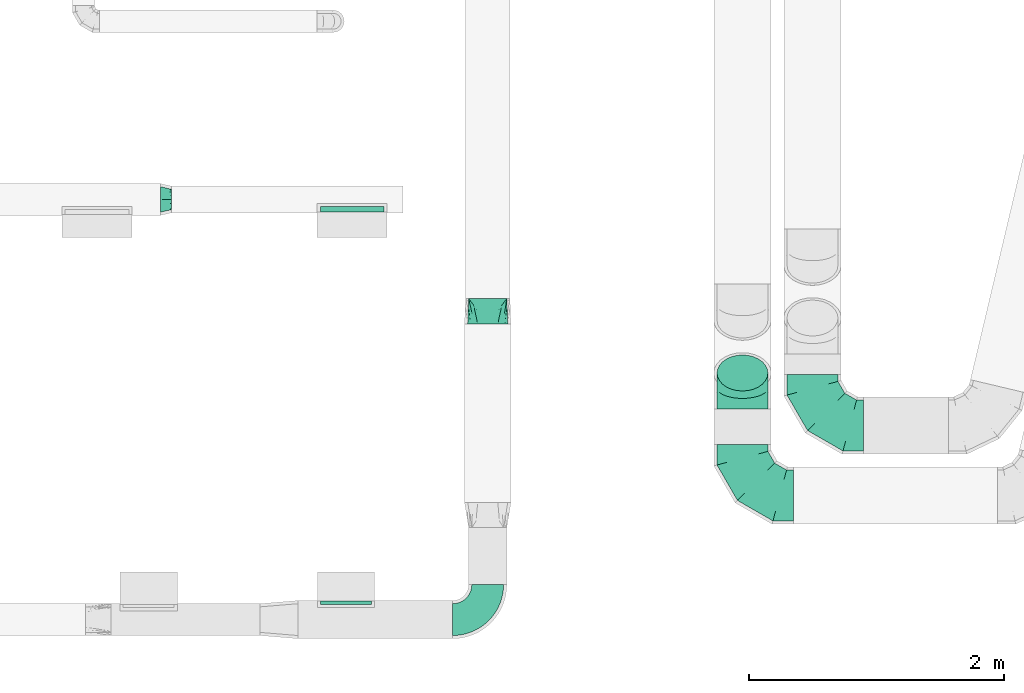
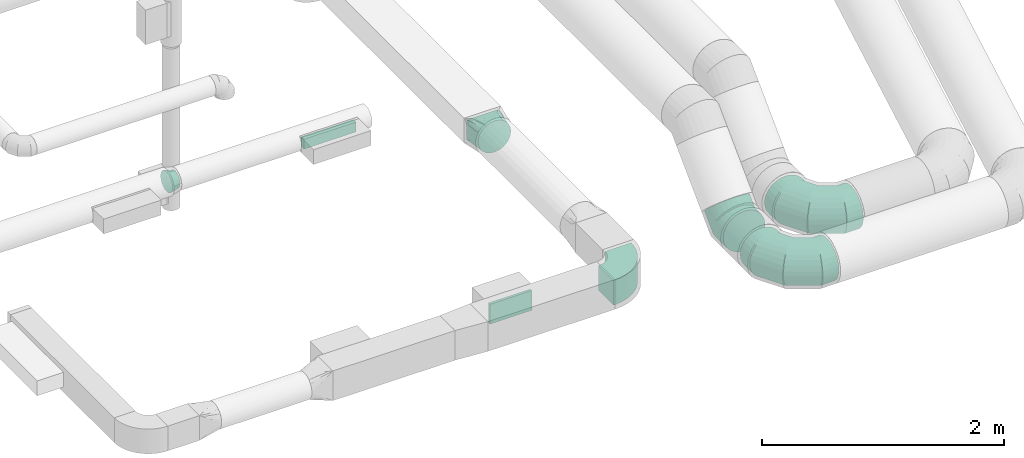
# One storey, part 52 of 97: 8 flow fittings.
"""IFC2X3 building model written with IfcOpenShell, lengths in millimetres."""

from ifc_helpers import new_model, entity, si_unit, converted_unit, derived_unit, direction, frame, frame_2d, origin, origin_2d_with_axis, place, context, subcontext, project, spatial, polyline, circle_curve, parameter, trimmed, segment, composite_curve, rectangle, outline, extrude, faceted_brep, source, transform, mapped, material, type_object, type_shapes, element, save


model = new_model("IFC2X3")

# Units and contexts
model_context = context("Model", 3, precision=0.01, world=origin(), true_north=direction((6.12303176911189e-17, 1.0)))
body_context = subcontext(model_context, "Body", "Model", "MODEL_VIEW")
ifc_project = project(units=[si_unit("LENGTHUNIT", "METRE", prefix="MILLI"), si_unit("AREAUNIT", "SQUARE_METRE"), si_unit("VOLUMEUNIT", "CUBIC_METRE"), converted_unit("PLANEANGLEUNIT", "DEGREE", entity("IfcRatioMeasure", 0.0174532925199433), si_unit("PLANEANGLEUNIT", "RADIAN"), dimensions=[0, 0, 0, 0, 0, 0, 0]), si_unit("MASSUNIT", "GRAM", prefix="KILO"), derived_unit("MASSDENSITYUNIT", [(si_unit("MASSUNIT", "GRAM", prefix="KILO"), 1), (si_unit("LENGTHUNIT", "METRE"), -3)]), derived_unit("MOMENTOFINERTIAUNIT", [(si_unit("LENGTHUNIT", "METRE"), 4)]), si_unit("TIMEUNIT", "SECOND"), si_unit("FREQUENCYUNIT", "HERTZ"), si_unit("THERMODYNAMICTEMPERATUREUNIT", "DEGREE_CELSIUS"), derived_unit("THERMALTRANSMITTANCEUNIT", [(si_unit("MASSUNIT", "GRAM", prefix="KILO"), 1), (si_unit("THERMODYNAMICTEMPERATUREUNIT", "KELVIN"), -1), (si_unit("TIMEUNIT", "SECOND"), -3)]), derived_unit("VOLUMETRICFLOWRATEUNIT", [(si_unit("LENGTHUNIT", "METRE"), 3), (si_unit("TIMEUNIT", "SECOND"), -1)]), derived_unit("MASSFLOWRATEUNIT", [(si_unit("MASSUNIT", "GRAM", prefix="KILO"), 1), (si_unit("TIMEUNIT", "SECOND"), -1)]), derived_unit("ROTATIONALFREQUENCYUNIT", [(si_unit("TIMEUNIT", "SECOND"), -1)]), si_unit("ELECTRICCURRENTUNIT", "AMPERE"), si_unit("ELECTRICVOLTAGEUNIT", "VOLT"), si_unit("POWERUNIT", "WATT"), si_unit("FORCEUNIT", "NEWTON", prefix="KILO"), si_unit("ILLUMINANCEUNIT", "LUX"), si_unit("LUMINOUSFLUXUNIT", "LUMEN"), si_unit("LUMINOUSINTENSITYUNIT", "CANDELA"), derived_unit("USERDEFINED", [(si_unit("MASSUNIT", "GRAM", prefix="KILO"), -1), (si_unit("LENGTHUNIT", "METRE"), -2), (si_unit("TIMEUNIT", "SECOND"), 3), (si_unit("LUMINOUSFLUXUNIT", "LUMEN"), 1)]), derived_unit("LINEARVELOCITYUNIT", [(si_unit("LENGTHUNIT", "METRE"), 1), (si_unit("TIMEUNIT", "SECOND"), -1)]), si_unit("PRESSUREUNIT", "PASCAL"), derived_unit("USERDEFINED", [(si_unit("LENGTHUNIT", "METRE"), -2), (si_unit("MASSUNIT", "GRAM", prefix="KILO"), 1), (si_unit("TIMEUNIT", "SECOND"), -2)]), derived_unit("LINEARFORCEUNIT", [(si_unit("MASSUNIT", "GRAM", prefix="KILO"), 1), (si_unit("LENGTHUNIT", "METRE"), 1), (si_unit("TIMEUNIT", "SECOND"), -2), (si_unit("LENGTHUNIT", "METRE"), -1)]), derived_unit("PLANARFORCEUNIT", [(si_unit("MASSUNIT", "GRAM", prefix="KILO"), 1), (si_unit("LENGTHUNIT", "METRE"), 1), (si_unit("TIMEUNIT", "SECOND"), -2), (si_unit("LENGTHUNIT", "METRE"), -2)])], contexts=[model_context])

# Site, building, storey
site_placement = place(None, origin())
site = spatial("IfcSite", under=ifc_project, at=site_placement, CompositionType="ELEMENT")
building_placement = place(site_placement, origin())
building = spatial("IfcBuilding", under=site, at=building_placement, CompositionType="ELEMENT")
storey_placement = place(building_placement, frame((0.0, 0.0, -4900.0)))
storey = spatial("IfcBuildingStorey", under=building, at=storey_placement, CompositionType="ELEMENT", Elevation=-4900.0)

# Flow fittings
ifc_material = material()
duct_fitting_type_1 = type_object("IfcDuctFittingType", PredefinedType="NOTDEFINED", material=ifc_material)
shared_shape_1 = source(origin(), body_context, "Body", "SweptSolid", [
    extrude(rectangle(XDim=26.0960000000006, YDim=400.0, at=origin_2d_with_axis()), frame((6.95, 0.0, -100.0)), (0.0, 0.0, 1.0), 200.0),
])
type_shapes(duct_fitting_type_1, [shared_shape_1])
flow_fitting_1_placement = place(storey_placement, frame((48350.01, 398.87, 4200.0), z_axis=(0.0, 0.0, -1.0), x_axis=(0.0, 1.0, 0.0)))
element("IfcFlowFitting", 1, at=flow_fitting_1_placement, inside=storey, type_object=duct_fitting_type_1, material=ifc_material, context=body_context, shape_type="MappedRepresentation", body=[
    mapped(shared_shape_1, transform((0.0, 0.0, 0.0), scale=1.0)),
])
duct_fitting_type_2 = type_object("IfcDuctFittingType", PredefinedType="NOTDEFINED", material=ifc_material)
shared_shape_2 = source(origin(), body_context, "Body", "SweptSolid", [
    extrude(rectangle(XDim=43.646020016029, YDim=500.0, at=origin_2d_with_axis()), frame((-1.82, 0.0, -50.0)), (0.0, 0.0, 1.0), 100.0),
])
type_shapes(duct_fitting_type_2, [shared_shape_2])
flow_fitting_2_placement = place(storey_placement, frame((48398.45, 3493.53, 4050.0), z_axis=(0.0, 0.0, -1.0), x_axis=(0.0, -1.0, 0.0)))
element("IfcFlowFitting", 2, at=flow_fitting_2_placement, inside=storey, type_object=duct_fitting_type_2, material=ifc_material, context=body_context, shape_type="MappedRepresentation", body=[
    mapped(shared_shape_2, transform((0.0, 0.0, 0.0), scale=1.0)),
])
duct_fitting_type_3 = type_object("IfcDuctFittingType", PredefinedType="NOTDEFINED", material=ifc_material)
shared_shape_3 = source(origin(), body_context, "Body", "Brep", [
    faceted_brep([(-165.69, 0.0, -200.0), (-165.69, -44.5, -194.99), (-165.69, -86.78, -180.19), (-165.69, -124.7, -156.37), (-165.69, -156.37, -124.7), (-165.69, -180.19, -86.78), (-165.69, -194.99, -44.5), (-165.69, -200.0, 0.0), (-165.69, -194.99, 44.5), (-165.69, -180.19, 86.78), (-165.69, -156.37, 124.7), (-165.69, -124.7, 156.37), (-165.69, -86.78, 180.19), (-165.69, -44.5, 194.99), (-165.69, 0.0, 200.0), (-165.69, 44.5, 194.99), (-165.69, 86.78, 180.19), (-165.69, 124.7, 156.37), (-165.69, 156.37, 124.7), (-165.69, 180.19, 86.78), (-165.69, 194.99, 44.5), (-165.69, 200.0, 0.0), (-165.69, 194.99, -44.5), (-165.69, 180.19, -86.78), (-165.69, 156.37, -124.7), (-165.69, 124.7, -156.37), (-165.69, 86.78, -180.19), (-165.69, 44.5, -194.99), (0.0, 0.0, 200.0), (-18.43, 44.5, 194.99), (-35.94, 86.78, 180.19), (-51.65, 124.7, 156.37), (-64.77, 156.37, 124.7), (-74.64, 180.19, 86.78), (-80.77, 194.99, 44.5), (-82.84, 200.0, 0.0), (-80.77, 194.99, -44.5), (-74.64, 180.19, -86.78), (-64.77, 156.37, -124.7), (-51.65, 124.7, -156.37), (-35.94, 86.78, -180.19), (-18.43, 44.5, -194.99), (0.0, 0.0, -200.0), (18.43, -44.5, -194.99), (35.94, -86.78, -180.19), (51.65, -124.7, -156.37), (64.77, -156.37, -124.7), (74.64, -180.19, -86.78), (80.77, -194.99, -44.5), (82.84, -200.0, 0.0), (80.77, -194.99, 44.5), (74.64, -180.19, 86.78), (64.77, -156.37, 124.7), (51.65, -124.7, 156.37), (35.94, -86.78, 180.19), (18.43, -44.5, 194.99), (117.16, 117.16, 200.0), (85.69, 148.63, 194.99), (55.8, 178.52, 180.19), (28.98, 205.33, 156.37), (6.59, 227.72, 124.7), (-10.26, 244.57, 86.78), (-20.72, 255.03, 44.5), (-24.26, 258.58, 0.0), (-20.72, 255.03, -44.5), (-10.26, 244.57, -86.78), (6.59, 227.72, -124.7), (28.98, 205.33, -156.37), (55.8, 178.52, -180.19), (85.69, 148.63, -194.99), (117.16, 117.16, -200.0), (148.63, 85.69, -194.99), (178.52, 55.8, -180.19), (205.33, 28.98, -156.37), (227.72, 6.59, -124.7), (244.57, -10.26, -86.78), (255.03, -20.72, -44.5), (258.58, -24.26, 0.0), (255.03, -20.72, 44.5), (244.57, -10.26, 86.78), (227.72, 6.59, 124.7), (205.33, 28.98, 156.37), (178.52, 55.8, 180.19), (148.63, 85.69, 194.99)], [[[0, 1, 2, 3, 4, 5, 6, 7, 8, 9, 10, 11, 12, 13, 14, 15, 16, 17, 18, 19, 20, 21, 22, 23, 24, 25, 26, 27]], [[28, 29, 15, 14]], [[30, 31, 17, 16]], [[29, 30, 16, 15]], [[31, 32, 18, 17]], [[32, 33, 19, 18]], [[34, 35, 21, 20]], [[33, 34, 20, 19]], [[35, 36, 22, 21]], [[37, 38, 24, 23]], [[36, 37, 23, 22]], [[38, 39, 25, 24]], [[39, 40, 26, 25]], [[41, 42, 0, 27]], [[40, 41, 27, 26]], [[1, 0, 42, 43]], [[43, 44, 2, 1]], [[45, 3, 2, 44]], [[45, 46, 4, 3]], [[5, 4, 46, 47]], [[47, 48, 6, 5]], [[49, 7, 6, 48]], [[7, 49, 50, 8]], [[8, 50, 51, 9]], [[9, 51, 52, 10]], [[52, 53, 11, 10]], [[11, 53, 54, 12]], [[12, 54, 55, 13]], [[13, 55, 28, 14]], [[29, 28, 56, 57]], [[30, 29, 57, 58]], [[31, 30, 58, 59]], [[59, 60, 32, 31]], [[33, 32, 60, 61]], [[34, 33, 61, 62]], [[35, 34, 62, 63]], [[63, 64, 36, 35]], [[65, 66, 38, 37]], [[64, 65, 37, 36]], [[66, 67, 39, 38]], [[39, 67, 68, 40]], [[40, 68, 69, 41]], [[41, 69, 70, 42]], [[42, 70, 71, 43]], [[43, 71, 72, 44]], [[44, 72, 73, 45]], [[73, 74, 46, 45]], [[46, 74, 75, 47]], [[47, 75, 76, 48]], [[48, 76, 77, 49]], [[50, 49, 77, 78]], [[51, 50, 78, 79]], [[52, 51, 79, 80]], [[80, 81, 53, 52]], [[54, 53, 81, 82]], [[55, 54, 82, 83]], [[28, 55, 83, 56]], [[69, 68, 67, 66, 65, 64, 63, 62, 61, 60, 59, 58, 57, 56, 83, 82, 81, 80, 79, 78, 77, 76, 75, 74, 73, 72, 71, 70]]]),
])
type_shapes(duct_fitting_type_3, [shared_shape_3])
flow_fitting_3_placement = place(storey_placement, frame((51464.16, 2093.55, 2950.0), z_axis=(-1.0, 0.0, 0.0), x_axis=(0.0, -0.707106781186541, -0.707106781186554)))
element("IfcFlowFitting", 3, at=flow_fitting_3_placement, inside=storey, type_object=duct_fitting_type_3, material=ifc_material, context=body_context, shape_type="MappedRepresentation", body=[
    mapped(shared_shape_3, transform((0.0, 0.0, 0.0), scale=1.0)),
])
duct_fitting_type_4 = type_object("IfcDuctFittingType", PredefinedType="NOTDEFINED", material=ifc_material)
shared_shape_4 = source(origin(), body_context, "Body", "Brep", [
    faceted_brep([(-400.0, 0.0, -200.0), (-400.0, -44.5, -194.99), (-400.0, -86.78, -180.19), (-400.0, -124.7, -156.37), (-400.0, -156.37, -124.7), (-400.0, -180.19, -86.78), (-400.0, -194.99, -44.5), (-400.0, -200.0, 0.0), (-400.0, -194.99, 44.5), (-400.0, -180.19, 86.78), (-400.0, -156.37, 124.7), (-400.0, -124.7, 156.37), (-400.0, -86.78, 180.19), (-400.0, -44.5, 194.99), (-400.0, 0.0, 200.0), (-400.0, 44.5, 194.99), (-400.0, 86.78, 180.19), (-400.0, 124.7, 156.37), (-400.0, 156.37, 124.7), (-400.0, 180.19, 86.78), (-400.0, 194.99, 44.5), (-400.0, 200.0, 0.0), (-400.0, 194.99, -44.5), (-400.0, 180.19, -86.78), (-400.0, 156.37, -124.7), (-400.0, 124.7, -156.37), (-400.0, 86.78, -180.19), (-400.0, 44.5, -194.99), (-292.82, 0.0, 200.0), (-304.75, 44.5, 194.99), (-316.07, 86.78, 180.19), (-326.23, 124.7, 156.37), (-334.72, 156.37, 124.7), (-341.1, 180.19, 86.78), (-345.07, 194.99, 44.5), (-346.41, 200.0, 0.0), (-345.07, 194.99, -44.5), (-341.1, 180.19, -86.78), (-334.72, 156.37, -124.7), (-326.23, 124.7, -156.37), (-316.07, 86.78, -180.19), (-304.75, 44.5, -194.99), (-292.82, 0.0, -200.0), (-280.9, -44.5, -194.99), (-269.57, -86.78, -180.19), (-259.41, -124.7, -156.37), (-250.92, -156.37, -124.7), (-244.54, -180.19, -86.78), (-240.57, -194.99, -44.5), (-239.23, -200.0, 0.0), (-240.57, -194.99, 44.5), (-244.54, -180.19, 86.78), (-250.92, -156.37, 124.7), (-259.41, -124.7, 156.37), (-269.57, -86.78, 180.19), (-280.9, -44.5, 194.99), (-107.18, 107.18, 200.0), (-139.76, 139.76, 194.99), (-170.7, 170.7, 180.19), (-198.46, 198.46, 156.37), (-221.65, 221.65, 124.7), (-239.09, 239.09, 86.78), (-249.92, 249.92, 44.5), (-253.59, 253.59, 0.0), (-249.92, 249.92, -44.5), (-239.09, 239.09, -86.78), (-221.65, 221.65, -124.7), (-198.46, 198.46, -156.37), (-170.7, 170.7, -180.19), (-139.76, 139.76, -194.99), (-107.18, 107.18, -200.0), (-74.6, 74.6, -194.99), (-43.65, 43.65, -180.19), (-15.89, 15.89, -156.37), (7.29, -7.29, -124.7), (24.73, -24.73, -86.78), (35.56, -35.56, -44.5), (39.23, -39.23, 0.0), (35.56, -35.56, 44.5), (24.73, -24.73, 86.78), (7.29, -7.29, 124.7), (-15.89, 15.89, 156.37), (-43.65, 43.65, 180.19), (-74.6, 74.6, 194.99), (0.0, 292.82, 200.0), (-44.5, 304.75, 194.99), (-86.78, 316.07, 180.19), (-124.7, 326.23, 156.37), (-156.37, 334.72, 124.7), (-180.19, 341.1, 86.78), (-194.99, 345.07, 44.5), (-200.0, 346.41, 0.0), (-194.99, 345.07, -44.5), (-180.19, 341.1, -86.78), (-156.37, 334.72, -124.7), (-124.7, 326.23, -156.37), (-86.78, 316.07, -180.19), (-44.5, 304.75, -194.99), (0.0, 292.82, -200.0), (44.5, 280.9, -194.99), (86.78, 269.57, -180.19), (124.7, 259.41, -156.37), (156.37, 250.92, -124.7), (180.19, 244.54, -86.78), (194.99, 240.57, -44.5), (200.0, 239.23, 0.0), (194.99, 240.57, 44.5), (180.19, 244.54, 86.78), (156.37, 250.92, 124.7), (124.7, 259.41, 156.37), (86.78, 269.57, 180.19), (44.5, 280.9, 194.99), (-44.5, 400.0, -194.99), (-86.78, 400.0, -180.19), (-124.7, 400.0, -156.37), (-156.37, 400.0, -124.7), (-180.19, 400.0, -86.78), (-194.99, 400.0, -44.5), (-200.0, 400.0, 0.0), (-194.99, 400.0, 44.5), (-180.19, 400.0, 86.78), (-156.37, 400.0, 124.7), (-124.7, 400.0, 156.37), (-86.78, 400.0, 180.19), (-44.5, 400.0, 194.99), (0.0, 400.0, 200.0), (44.5, 400.0, 194.99), (86.78, 400.0, 180.19), (124.7, 400.0, 156.37), (156.37, 400.0, 124.7), (180.19, 400.0, 86.78), (194.99, 400.0, 44.5), (200.0, 400.0, 0.0), (194.99, 400.0, -44.5), (180.19, 400.0, -86.78), (156.37, 400.0, -124.7), (124.7, 400.0, -156.37), (86.78, 400.0, -180.19), (44.5, 400.0, -194.99), (0.0, 400.0, -200.0)], [[[0, 1, 2, 3, 4, 5, 6, 7, 8, 9, 10, 11, 12, 13, 14, 15, 16, 17, 18, 19, 20, 21, 22, 23, 24, 25, 26, 27]], [[28, 29, 15, 14]], [[30, 31, 17, 16]], [[29, 30, 16, 15]], [[31, 32, 18, 17]], [[32, 33, 19, 18]], [[34, 35, 21, 20]], [[33, 34, 20, 19]], [[35, 36, 22, 21]], [[37, 38, 24, 23]], [[36, 37, 23, 22]], [[38, 39, 25, 24]], [[39, 40, 26, 25]], [[41, 42, 0, 27]], [[40, 41, 27, 26]], [[1, 0, 42, 43]], [[43, 44, 2, 1]], [[45, 3, 2, 44]], [[45, 46, 4, 3]], [[5, 4, 46, 47]], [[47, 48, 6, 5]], [[49, 7, 6, 48]], [[7, 49, 50, 8]], [[8, 50, 51, 9]], [[9, 51, 52, 10]], [[52, 53, 11, 10]], [[11, 53, 54, 12]], [[12, 54, 55, 13]], [[13, 55, 28, 14]], [[56, 57, 29, 28]], [[58, 59, 31, 30]], [[57, 58, 30, 29]], [[59, 60, 32, 31]], [[60, 61, 33, 32]], [[62, 63, 35, 34]], [[61, 62, 34, 33]], [[63, 64, 36, 35]], [[65, 66, 38, 37]], [[64, 65, 37, 36]], [[66, 67, 39, 38]], [[67, 68, 40, 39]], [[69, 70, 42, 41]], [[68, 69, 41, 40]], [[43, 42, 70, 71]], [[71, 72, 44, 43]], [[73, 45, 44, 72]], [[73, 74, 46, 45]], [[47, 46, 74, 75]], [[75, 76, 48, 47]], [[77, 49, 48, 76]], [[50, 49, 77, 78]], [[51, 50, 78, 79]], [[52, 51, 79, 80]], [[80, 81, 53, 52]], [[54, 53, 81, 82]], [[55, 54, 82, 83]], [[28, 55, 83, 56]], [[84, 85, 57, 56]], [[86, 87, 59, 58]], [[85, 86, 58, 57]], [[87, 88, 60, 59]], [[88, 89, 61, 60]], [[90, 91, 63, 62]], [[89, 90, 62, 61]], [[91, 92, 64, 63]], [[93, 94, 66, 65]], [[92, 93, 65, 64]], [[94, 95, 67, 66]], [[95, 96, 68, 67]], [[97, 98, 70, 69]], [[96, 97, 69, 68]], [[71, 70, 98, 99]], [[99, 100, 72, 71]], [[101, 73, 72, 100]], [[101, 102, 74, 73]], [[75, 74, 102, 103]], [[103, 104, 76, 75]], [[105, 77, 76, 104]], [[78, 77, 105, 106]], [[79, 78, 106, 107]], [[80, 79, 107, 108]], [[108, 109, 81, 80]], [[82, 81, 109, 110]], [[83, 82, 110, 111]], [[56, 83, 111, 84]], [[112, 113, 114, 115, 116, 117, 118, 119, 120, 121, 122, 123, 124, 125, 126, 127, 128, 129, 130, 131, 132, 133, 134, 135, 136, 137, 138, 139]], [[85, 84, 125, 124]], [[86, 85, 124, 123]], [[87, 86, 123, 122]], [[122, 121, 88, 87]], [[89, 88, 121, 120]], [[90, 89, 120, 119]], [[91, 90, 119, 118]], [[91, 118, 117, 92]], [[92, 117, 116, 93]], [[93, 116, 115, 94]], [[115, 114, 95, 94]], [[95, 114, 113, 96]], [[96, 113, 112, 97]], [[97, 112, 139, 98]], [[98, 139, 138, 99]], [[99, 138, 137, 100]], [[100, 137, 136, 101]], [[136, 135, 102, 101]], [[102, 135, 134, 103]], [[103, 134, 133, 104]], [[104, 133, 132, 105]], [[106, 105, 132, 131]], [[107, 106, 131, 130]], [[108, 107, 130, 129]], [[129, 128, 109, 108]], [[110, 109, 128, 127]], [[111, 110, 127, 126]], [[84, 111, 126, 125]]]),
])
type_shapes(duct_fitting_type_4, [shared_shape_4])
for number, where, z_axis, x_axis in (
    (4, (52014.1, 1798.23, 2950.0), (0.0, 0.0, 1.0), (0.0, -1.0, 0.0)),
    (5, (51464.16, 1248.73, 2950.0), (0.0, -9.44473526813366e-09, 1.0), (0.0, -1.0, -9.44473526813366e-09)),
):
    element("IfcFlowFitting", number, at=place(storey_placement, frame(where, z_axis=z_axis, x_axis=x_axis)), inside=storey, type_object=duct_fitting_type_4, material=ifc_material, context=body_context, shape_type="MappedRepresentation", body=[
        mapped(shared_shape_4, transform((0.0, 0.0, 0.0), scale=1.0)),
    ])
duct_fitting_type_5 = type_object("IfcDuctFittingType", PredefinedType="NOTDEFINED", material=ifc_material)
shared_shape_5 = source(origin(), body_context, "Body", "Brep", [
    faceted_brep([(85.0, -30.61, -73.91), (85.0, -15.31, -76.96), (85.0, 0.0, -80.0), (85.0, 15.31, -76.96), (85.0, 30.61, -73.91), (85.0, 43.59, -65.24), (85.0, 56.57, -56.57), (85.0, 65.24, -43.59), (85.0, 73.91, -30.61), (85.0, 76.96, -15.31), (85.0, 80.0, 0.0), (85.0, 76.96, 15.31), (85.0, 73.91, 30.61), (85.0, 65.24, 43.59), (85.0, 56.57, 56.57), (85.0, 43.59, 65.24), (85.0, 30.61, 73.91), (85.0, 15.31, 76.96), (85.0, 0.0, 80.0), (85.0, -15.31, 76.96), (85.0, -30.61, 73.91), (85.0, -43.59, 65.24), (85.0, -56.57, 56.57), (85.0, -65.24, 43.59), (85.0, -73.91, 30.61), (85.0, -76.96, 15.31), (85.0, -80.0, 0.0), (85.0, -76.96, -15.31), (85.0, -73.91, -30.61), (85.0, -65.24, -43.59), (85.0, -56.57, -56.57), (85.0, -43.59, -65.24), (0.0, -100.0, 0.0), (0.0, -95.11, 30.9), (0.0, -80.9, 58.78), (0.0, -58.78, 80.9), (0.0, -30.9, 95.11), (0.0, 0.0, 100.0), (0.0, 30.9, 95.11), (0.0, 58.78, 80.9), (0.0, 80.9, 58.78), (0.0, 95.11, 30.9), (0.0, 100.0, 0.0), (0.0, 95.11, -30.9), (0.0, 80.9, -58.78), (0.0, 58.78, -80.9), (0.0, 30.9, -95.11), (0.0, 0.0, -100.0), (0.0, -30.9, -95.11), (0.0, -58.78, -80.9), (0.0, -80.9, -58.78), (0.0, -95.11, -30.9)], [[[0, 1, 2, 3, 4, 5, 6, 7, 8, 9, 10, 11, 12, 13, 14, 15, 16, 17, 18, 19, 20, 21, 22, 23, 24, 25, 26, 27, 28, 29, 30, 31]], [[32, 33, 34, 35, 36, 37, 38, 39, 40, 41, 42, 43, 44, 45, 46, 47, 48, 49, 50, 51]], [[37, 17, 38]], [[16, 39, 38]], [[40, 14, 13, 12]], [[15, 14, 39, 16]], [[41, 12, 11]], [[10, 42, 11]], [[17, 16, 38]], [[40, 12, 41]], [[11, 42, 41]], [[17, 37, 18]], [[14, 40, 39]], [[32, 25, 33]], [[24, 34, 33]], [[35, 22, 21, 20]], [[23, 22, 34, 24]], [[36, 20, 19]], [[18, 37, 19]], [[25, 24, 33]], [[35, 20, 36]], [[19, 37, 36]], [[25, 32, 26]], [[22, 35, 34]], [[47, 1, 48]], [[0, 49, 48]], [[50, 30, 29, 28]], [[31, 30, 49, 0]], [[51, 28, 27]], [[26, 32, 27]], [[1, 0, 48]], [[50, 28, 51]], [[27, 32, 51]], [[1, 47, 2]], [[30, 50, 49]], [[42, 9, 43]], [[8, 44, 43]], [[45, 6, 5, 4]], [[7, 6, 44, 8]], [[46, 4, 3]], [[2, 47, 3]], [[9, 8, 43]], [[45, 4, 46]], [[3, 47, 46]], [[9, 42, 10]], [[6, 45, 44]]]),
])
type_shapes(duct_fitting_type_5, [shared_shape_5])
flow_fitting_4_placement = place(storey_placement, frame((46894.14, 3573.53, 4050.0)))
element("IfcFlowFitting", 6, at=flow_fitting_4_placement, inside=storey, type_object=duct_fitting_type_5, material=ifc_material, context=body_context, shape_type="MappedRepresentation", body=[
    mapped(shared_shape_5, transform((0.0, 0.0, 0.0), scale=1.0)),
])
duct_fitting_type_6 = type_object("IfcDuctFittingType", PredefinedType="NOTDEFINED", material=ifc_material)
shared_shape_6 = source(origin(), body_context, "Body", "Brep", [
    faceted_brep([(200.0, 78.75, 136.4), (200.0, 59.76, 144.27), (200.0, 40.76, 152.13), (200.0, 27.93, 153.82), (200.0, 15.1, 155.51), (200.0, 0.0, 157.5), (200.0, -15.1, 155.51), (200.0, -27.93, 153.82), (200.0, -40.76, 152.13), (200.0, -59.76, 144.27), (200.0, -78.75, 136.4), (200.0, -95.06, 123.88), (200.0, -111.37, 111.37), (200.0, -123.88, 95.06), (200.0, -136.4, 78.75), (200.0, -144.27, 59.76), (200.0, -152.13, 40.76), (200.0, -153.82, 27.93), (200.0, -155.51, 15.1), (200.0, -157.5, 0.0), (200.0, -155.51, -15.1), (200.0, -153.82, -27.93), (200.0, -152.13, -40.76), (200.0, -144.27, -59.76), (200.0, -136.4, -78.75), (200.0, -123.88, -95.06), (200.0, -111.37, -111.37), (200.0, -95.06, -123.88), (200.0, -78.75, -136.4), (200.0, -59.76, -144.27), (200.0, -40.76, -152.13), (200.0, -27.93, -153.82), (200.0, -15.1, -155.51), (200.0, 0.0, -157.5), (200.0, 15.1, -155.51), (200.0, 27.93, -153.82), (200.0, 40.76, -152.13), (200.0, 59.76, -144.27), (200.0, 78.75, -136.4), (200.0, 95.06, -123.88), (200.0, 111.37, -111.37), (200.0, 123.88, -95.06), (200.0, 136.4, -78.75), (200.0, 144.27, -59.76), (200.0, 152.13, -40.76), (200.0, 153.82, -27.93), (200.0, 155.51, -15.1), (200.0, 157.5, 0.0), (200.0, 155.51, 15.1), (200.0, 153.82, 27.93), (200.0, 152.13, 40.76), (200.0, 144.27, 59.76), (200.0, 136.4, 78.75), (200.0, 123.88, 95.06), (200.0, 111.37, 111.37), (200.0, 95.06, 123.88), (0.0, -150.0, 100.0), (0.0, 150.0, 100.0), (0.0, 150.0, -100.0), (0.0, -150.0, -100.0), (128.09, -53.94, 136.82), (104.11, -71.91, 129.93), (78.09, -91.44, 122.45), (100.0, -127.21, 108.95), (26.03, -130.48, 107.48), (52.06, -151.95, 73.97), (26.03, -150.98, 86.99), (78.09, -152.93, 60.96), (104.11, -153.9, 47.94), (128.09, -154.8, 35.96), (176.03, -17.98, 150.61), (152.06, -35.96, 143.72), (152.06, -155.7, 23.97), (176.03, -156.6, 11.99), (52.06, -110.96, 114.97), (26.03, -150.98, -86.99), (52.06, -151.95, -73.97), (78.09, -152.93, -60.96), (104.11, -153.9, -47.94), (128.09, -154.8, -35.96), (152.06, -155.7, -23.97), (176.03, -156.6, -11.99), (100.0, -133.95, -102.21), (52.06, -110.96, -114.97), (26.03, -130.48, -107.48), (78.09, -91.44, -122.45), (104.11, -71.91, -129.93), (128.09, -53.94, -136.82), (152.06, -35.96, -143.72), (176.03, -17.98, -150.61), (26.03, 130.48, -107.48), (52.06, 110.96, -114.97), (78.09, 91.44, -122.45), (104.11, 71.91, -129.93), (128.09, 53.94, -136.82), (152.06, 35.96, -143.72), (176.03, 17.98, -150.61), (100.0, 127.21, -108.95), (52.06, 151.95, -73.97), (26.03, 150.98, -86.99), (78.09, 152.93, -60.96), (104.11, 153.9, -47.94), (128.09, 154.8, -35.96), (152.06, 155.7, -23.97), (176.03, 156.6, -11.99), (26.03, 150.98, 86.99), (52.06, 151.95, 73.97), (78.09, 152.93, 60.96), (104.11, 153.9, 47.94), (128.09, 154.8, 35.96), (152.06, 155.7, 23.97), (176.03, 156.6, 11.99), (100.0, 133.95, 102.21), (52.06, 110.96, 114.97), (26.03, 130.48, 107.48), (78.09, 91.44, 122.45), (104.11, 71.91, 129.93), (128.09, 53.94, 136.82), (152.06, 35.96, 143.72), (176.03, 17.98, 150.61)], [[[0, 1, 2, 3, 4, 5, 6, 7, 8, 9, 10, 11, 12, 13, 14, 15, 16, 17, 18, 19, 20, 21, 22, 23, 24, 25, 26, 27, 28, 29, 30, 31, 32, 33, 34, 35, 36, 37, 38, 39, 40, 41, 42, 43, 44, 45, 46, 47, 48, 49, 50, 51, 52, 53, 54, 55]], [[56, 57, 58, 59]], [[60, 61, 62, 9]], [[63, 11, 64]], [[13, 12, 63]], [[8, 60, 9]], [[9, 62, 10]], [[65, 14, 13]], [[13, 63, 66]], [[15, 67, 68, 69]], [[70, 71, 60, 8, 7, 6, 5]], [[17, 16, 69, 72, 73, 19, 18]], [[15, 14, 67]], [[15, 69, 16]], [[14, 65, 67]], [[11, 74, 64]], [[11, 10, 74]], [[56, 63, 64]], [[11, 63, 12]], [[13, 66, 65]], [[63, 56, 66]], [[62, 74, 10]], [[73, 72, 69, 68, 67, 65, 66, 56, 59, 75, 76, 77, 78, 79, 80, 81, 19]], [[79, 78, 77, 23]], [[82, 25, 75]], [[27, 26, 82]], [[22, 79, 23]], [[23, 77, 24]], [[83, 28, 27]], [[27, 82, 84]], [[29, 85, 86, 87]], [[81, 80, 79, 22, 21, 20, 19]], [[31, 30, 87, 88, 89, 33, 32]], [[29, 28, 85]], [[29, 87, 30]], [[28, 83, 85]], [[25, 76, 75]], [[25, 24, 76]], [[59, 82, 75]], [[25, 82, 26]], [[27, 84, 83]], [[82, 59, 84]], [[77, 76, 24]], [[89, 88, 87, 86, 85, 83, 84, 59, 58, 90, 91, 92, 93, 94, 95, 96, 33]], [[94, 93, 92, 37]], [[97, 39, 90]], [[41, 40, 97]], [[36, 94, 37]], [[37, 92, 38]], [[98, 42, 41]], [[41, 97, 99]], [[43, 100, 101, 102]], [[96, 95, 94, 36, 35, 34, 33]], [[45, 44, 102, 103, 104, 47, 46]], [[43, 42, 100]], [[43, 102, 44]], [[42, 98, 100]], [[39, 91, 90]], [[39, 38, 91]], [[58, 97, 90]], [[39, 97, 40]], [[41, 99, 98]], [[97, 58, 99]], [[92, 91, 38]], [[58, 57, 105, 106, 107, 108, 109, 110, 111, 47, 104, 103, 102, 101, 100, 98, 99]], [[109, 108, 107, 51]], [[112, 53, 105]], [[55, 54, 112]], [[50, 109, 51]], [[51, 107, 52]], [[113, 0, 55]], [[55, 112, 114]], [[1, 115, 116, 117]], [[111, 110, 109, 50, 49, 48, 47]], [[3, 2, 117, 118, 119, 5, 4]], [[1, 0, 115]], [[1, 117, 2]], [[0, 113, 115]], [[53, 106, 105]], [[53, 52, 106]], [[57, 112, 105]], [[53, 112, 54]], [[55, 114, 113]], [[112, 57, 114]], [[107, 106, 52]], [[57, 56, 64, 74, 62, 61, 60, 71, 70, 5, 119, 118, 117, 116, 115, 113, 114]]]),
])
type_shapes(duct_fitting_type_6, [shared_shape_6])
flow_fitting_5_placement = place(storey_placement, frame((49463.6, 2795.77, 4200.0), z_axis=(0.0, 0.0, 1.0), x_axis=(0.0, -1.0, 0.0)))
element("IfcFlowFitting", 7, at=flow_fitting_5_placement, inside=storey, type_object=duct_fitting_type_6, material=ifc_material, context=body_context, shape_type="MappedRepresentation", body=[
    mapped(shared_shape_6, transform((0.0, 0.0, 0.0), scale=1.0)),
])
duct_fitting_type_7 = type_object("IfcDuctFittingType", PredefinedType="NOTDEFINED", material=ifc_material)
shared_shape_7 = source(origin(), body_context, "Body", "SweptSolid", [
    extrude(outline(composite_curve([segment(polyline([(-262.5, -137.5), (-12.5, -137.5)]), True, "CONTINUOUS"), segment(trimmed(circle_curve(frame_2d((137.5, -137.5), x_axis=(0.0, 1.0)), 150.0), [parameter(0.0)], [parameter(90.0000000000001)], True, "PARAMETER"), False, "CONTINUOUS"), segment(polyline([(137.5, 12.5), (137.5, 262.5)]), True, "CONTINUOUS"), segment(trimmed(circle_curve(frame_2d((137.5, -137.5), x_axis=(0.0, 1.0)), 400.0), [parameter(0.0)], [parameter(90.0000000000001)], True, "PARAMETER"), True, "CONTINUOUS")], self_intersect=False)), frame((-137.5, 137.5, -125.0), z_axis=(0.0, 0.0, 1.0), x_axis=(-1.0, 0.0, 0.0)), (0.0, 0.0, 1.0), 250.0),
])
type_shapes(duct_fitting_type_7, [shared_shape_7])
flow_fitting_6_placement = place(storey_placement, frame((49463.6, 273.87, 4200.0)))
element("IfcFlowFitting", 8, at=flow_fitting_6_placement, inside=storey, type_object=duct_fitting_type_7, material=ifc_material, context=body_context, shape_type="MappedRepresentation", body=[
    mapped(shared_shape_7, transform((0.0, 0.0, 0.0), scale=1.0)),
])

save(model, "model.ifc")
